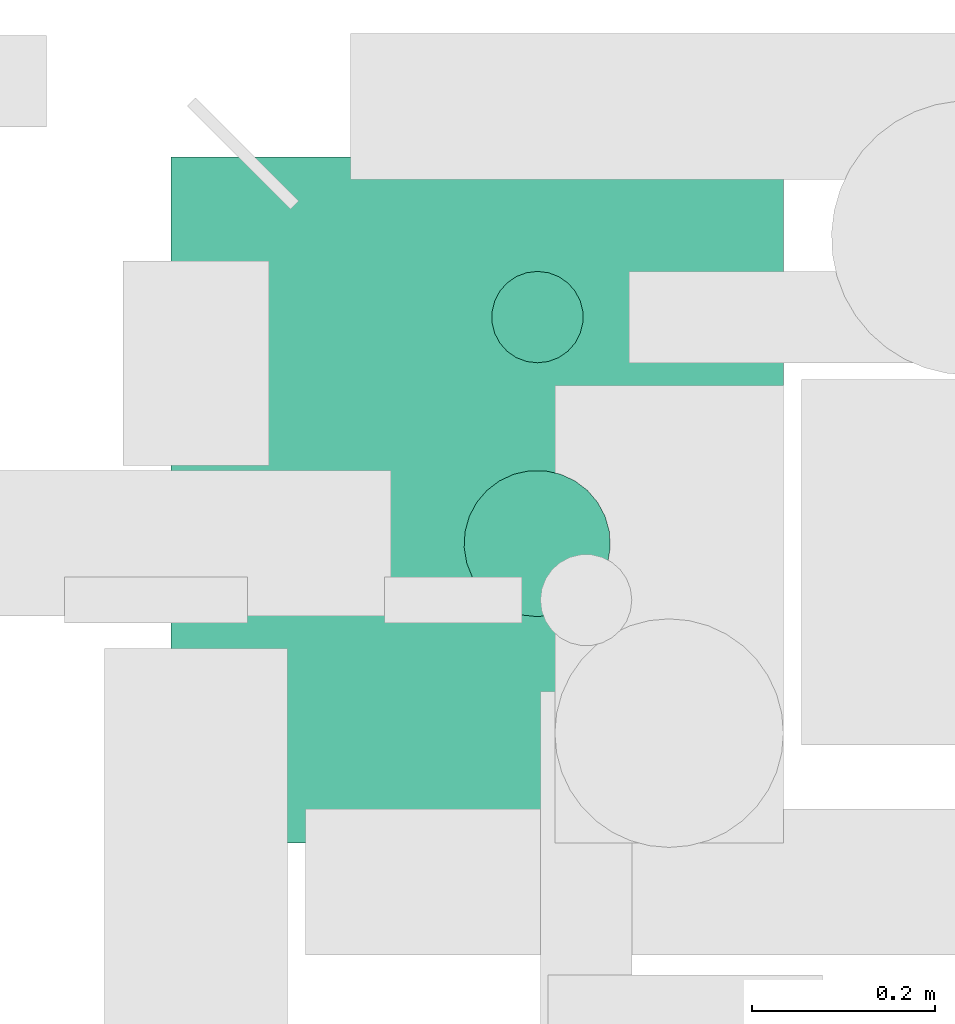
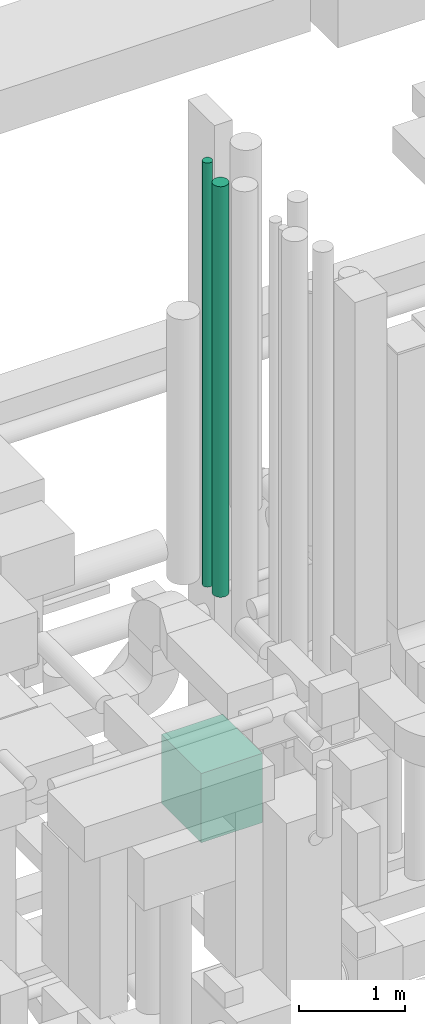
# One storey, part 57 of 337: 3 flow segments.
"""IFC2X3 building model written with IfcOpenShell, lengths in millimetres."""

from ifc_helpers import new_model, entity, si_unit, converted_unit, derived_unit, direction, frame, origin, origin_2d_with_axis, place, context, subcontext, project, spatial, rectangle, circle, extrude, type_object, element, save


model = new_model("IFC2X3")

# Units and contexts
model_context = context("Model", 3, precision=0.01, world=origin(), true_north=direction((6.12303176911189e-17, 1.0)))
body_context = subcontext(model_context, "Body", "Model", "MODEL_VIEW")
ifc_project = project(units=[si_unit("LENGTHUNIT", "METRE", prefix="MILLI"), si_unit("AREAUNIT", "SQUARE_METRE"), si_unit("VOLUMEUNIT", "CUBIC_METRE"), converted_unit("PLANEANGLEUNIT", "DEGREE", entity("IfcRatioMeasure", 0.0174532925199433), si_unit("PLANEANGLEUNIT", "RADIAN"), dimensions=[0, 0, 0, 0, 0, 0, 0]), si_unit("MASSUNIT", "GRAM", prefix="KILO"), derived_unit("MASSDENSITYUNIT", [(si_unit("MASSUNIT", "GRAM", prefix="KILO"), 1), (si_unit("LENGTHUNIT", "METRE"), -3)]), derived_unit("MOMENTOFINERTIAUNIT", [(si_unit("LENGTHUNIT", "METRE"), 4)]), si_unit("TIMEUNIT", "SECOND"), si_unit("FREQUENCYUNIT", "HERTZ"), si_unit("THERMODYNAMICTEMPERATUREUNIT", "DEGREE_CELSIUS"), derived_unit("THERMALTRANSMITTANCEUNIT", [(si_unit("MASSUNIT", "GRAM", prefix="KILO"), 1), (si_unit("THERMODYNAMICTEMPERATUREUNIT", "KELVIN"), -1), (si_unit("TIMEUNIT", "SECOND"), -3)]), derived_unit("VOLUMETRICFLOWRATEUNIT", [(si_unit("LENGTHUNIT", "METRE"), 3), (si_unit("TIMEUNIT", "SECOND"), -1)]), derived_unit("MASSFLOWRATEUNIT", [(si_unit("MASSUNIT", "GRAM", prefix="KILO"), 1), (si_unit("TIMEUNIT", "SECOND"), -1)]), derived_unit("ROTATIONALFREQUENCYUNIT", [(si_unit("TIMEUNIT", "SECOND"), -1)]), si_unit("ELECTRICCURRENTUNIT", "AMPERE"), si_unit("ELECTRICVOLTAGEUNIT", "VOLT"), si_unit("POWERUNIT", "WATT"), si_unit("FORCEUNIT", "NEWTON", prefix="KILO"), si_unit("ILLUMINANCEUNIT", "LUX"), si_unit("LUMINOUSFLUXUNIT", "LUMEN"), si_unit("LUMINOUSINTENSITYUNIT", "CANDELA"), derived_unit("USERDEFINED", [(si_unit("MASSUNIT", "GRAM", prefix="KILO"), -1), (si_unit("LENGTHUNIT", "METRE"), -2), (si_unit("TIMEUNIT", "SECOND"), 3), (si_unit("LUMINOUSFLUXUNIT", "LUMEN"), 1)]), derived_unit("LINEARVELOCITYUNIT", [(si_unit("LENGTHUNIT", "METRE"), 1), (si_unit("TIMEUNIT", "SECOND"), -1)]), si_unit("PRESSUREUNIT", "PASCAL"), derived_unit("USERDEFINED", [(si_unit("LENGTHUNIT", "METRE"), -2), (si_unit("MASSUNIT", "GRAM", prefix="KILO"), 1), (si_unit("TIMEUNIT", "SECOND"), -2)]), derived_unit("LINEARFORCEUNIT", [(si_unit("MASSUNIT", "GRAM", prefix="KILO"), 1), (si_unit("LENGTHUNIT", "METRE"), 1), (si_unit("TIMEUNIT", "SECOND"), -2), (si_unit("LENGTHUNIT", "METRE"), -1)]), derived_unit("PLANARFORCEUNIT", [(si_unit("MASSUNIT", "GRAM", prefix="KILO"), 1), (si_unit("LENGTHUNIT", "METRE"), 1), (si_unit("TIMEUNIT", "SECOND"), -2), (si_unit("LENGTHUNIT", "METRE"), -2)])], contexts=[model_context])

# Site, building, storey
site_placement = place(None, origin())
site = spatial("IfcSite", under=ifc_project, at=site_placement, CompositionType="ELEMENT")
building_placement = place(site_placement, origin())
building = spatial("IfcBuilding", under=site, at=building_placement, CompositionType="ELEMENT")
storey_placement = place(building_placement, origin())
storey = spatial("IfcBuildingStorey", under=building, at=storey_placement, CompositionType="ELEMENT", Elevation=0.0)

# Flow segments
duct_segment_type_1 = type_object("IfcDuctSegmentType", PredefinedType="NOTDEFINED")
flow_segment_1_placement = place(storey_placement, frame((55050.02, 11530.6, 28400.0)))
element("IfcFlowSegment", 1, at=flow_segment_1_placement, inside=storey, type_object=duct_segment_type_1, context=body_context, shape_type="SweptSolid", body=[
    extrude(rectangle(XDim=749.999999999998, YDim=670.000000000004, at=origin_2d_with_axis()), frame((335.0, 375.0, 0.0), z_axis=(0.0, 0.0, 1.0), x_axis=(0.0, -1.0, 0.0)), (0.0, 0.0, 1.0), 800.0),
])
duct_segment_type_2 = type_object("IfcDuctSegmentType", PredefinedType="NOTDEFINED")
flow_segment_2_placement = place(storey_placement, frame((55399.4, 12054.04, 30900.0)))
element("IfcFlowSegment", 2, at=flow_segment_2_placement, inside=storey, type_object=duct_segment_type_2, context=body_context, shape_type="SweptSolid", body=[
    extrude(circle(Radius=50.0, at=origin_2d_with_axis()), frame((51.6, 51.6, 0.0), z_axis=(0.0, 0.0, 1.0), x_axis=(0.0, -1.0, 0.0)), (0.0, 0.0, 1.0), 4901.30348748862),
])
flow_segment_3_placement = place(storey_placement, frame((55369.11, 11776.4, 30955.0)))
element("IfcFlowSegment", 3, at=flow_segment_3_placement, inside=storey, type_object=duct_segment_type_2, context=body_context, shape_type="SweptSolid", body=[
    extrude(circle(Radius=80.0, at=origin_2d_with_axis()), frame((81.6, 81.6, 0.0), z_axis=(0.0, 0.0, 1.0), x_axis=(0.0, -1.0, 0.0)), (0.0, 0.0, 1.0), 4744.99999999963),
])

save(model, "model.ifc")
